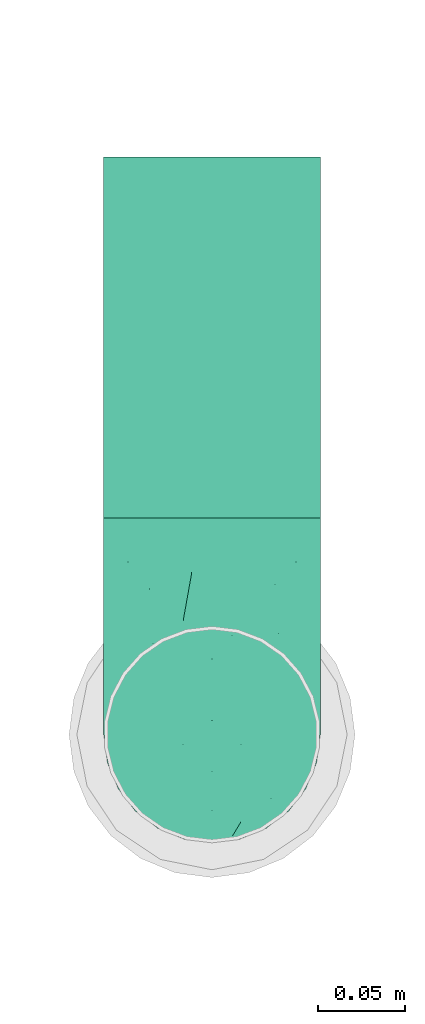
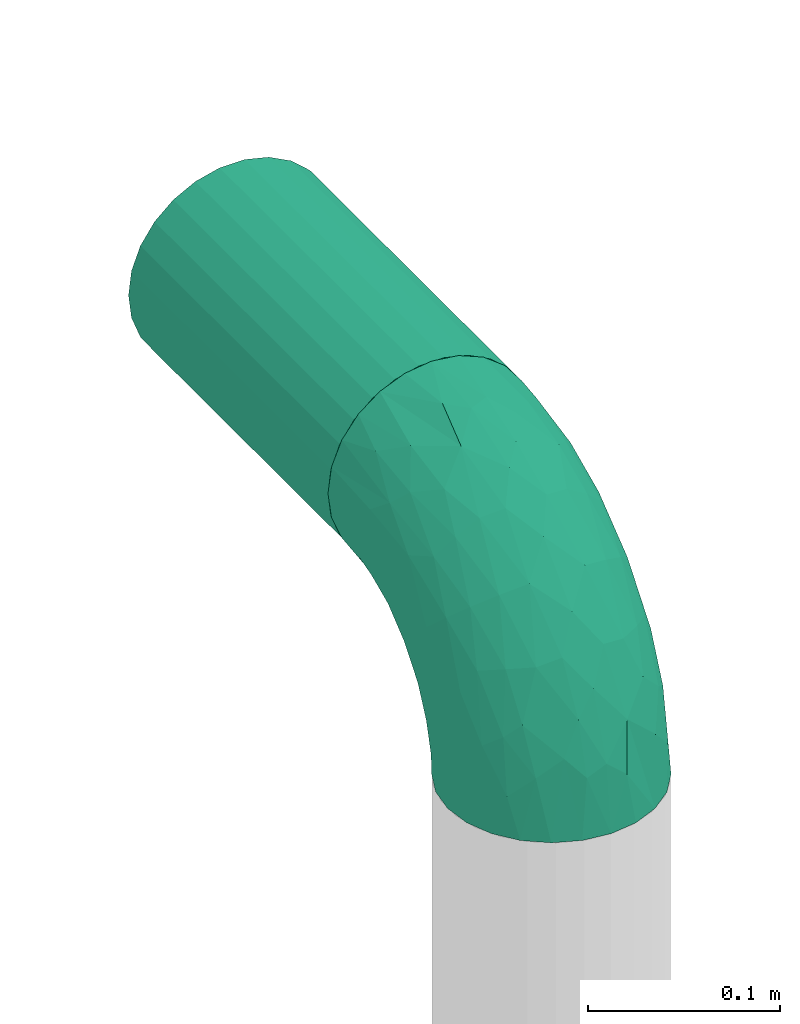
# One storey, part 51 of 103: 1 flow fitting, 1 flow segment.
"""IFC2X3 building model written with IfcOpenShell, lengths in millimetres."""

import ifcopenshell
import ifcopenshell.guid

model = None  # the IFC model being written
_history = None  # IfcOwnerHistory: only IFC2X3 demands one
_inside = {}  # id of a spatial element -> (the spatial element, [elements in it])
_under = {}  # id of a project, library or spatial element -> (it, [spatial elements below it])
_declared = {}  # id of a project -> (the project, [libraries it declares])
_typed = {}  # id of a type object -> (the type object, [elements of that type])
_made_of = {}  # id of a material, layer set ... -> (it, [elements and type objects made of it])


def new_model(schema):
    """Start an empty IFC model of exactly this schema.

    Asked for "IFC4X3", IfcOpenShell would pick the latest addendum, in which some entities
    have other attributes; the version numbers below select the first issue.
    IFC2X3 requires an IfcOwnerHistory on every rooted entity: one is made here for all.
    """
    global model, _history
    if schema == "IFC4X3":
        model = ifcopenshell.file(schema_version=(4, 3, 0, 0))
    else:
        model = ifcopenshell.file(schema=schema)
    _inside.clear()
    _under.clear()
    _declared.clear()
    _typed.clear()
    _made_of.clear()
    _history = None
    if model.schema == "IFC2X3":
        org = make("IfcOrganization", Name="unknown")
        user = make(
            "IfcPersonAndOrganization",
            ThePerson=make("IfcPerson", FamilyName="unknown"),
            TheOrganization=org,
        )
        app = make(
            "IfcApplication",
            ApplicationDeveloper=org,
            Version="unknown",
            ApplicationFullName="unknown",
            ApplicationIdentifier="unknown",
        )
        _history = make(
            "IfcOwnerHistory",
            OwningUser=user,
            OwningApplication=app,
            ChangeAction="ADDED",
            CreationDate=0,
        )
    return model


def make(cls, **values):
    """One entity of the class cls with the attributes given. An attribute that is None is left unset."""
    return model.create_entity(
        cls, **{name: value for name, value in values.items() if value is not None}
    )


def entity(cls, *values):
    """Any entity or typed value of the class cls, its attributes in the order of the schema. None: left unset."""
    e = model.create_entity(cls)
    for i, value in enumerate(values):
        if value is not None:
            e[i] = value
    return e


def rooted(cls, **values):
    """An entity with a GlobalId (a new one), such as an element, a storey or a relation."""
    return make(cls, GlobalId=ifcopenshell.guid.new(), OwnerHistory=_history, **values)


def si_unit(unit_type, name, prefix=None):
    """IfcSIUnit, for example si_unit("LENGTHUNIT", "METRE", prefix="MILLI")."""
    return make("IfcSIUnit", UnitType=unit_type, Prefix=prefix, Name=name)


def converted_unit(unit_type, name, factor, base, dimensions=None, offset=None):
    """IfcConversionBasedUnit, such as the inch: factor (a typed value) times the base unit."""
    return make(
        "IfcConversionBasedUnit"
        if offset is None
        else "IfcConversionBasedUnitWithOffset",
        ConversionOffset=offset,
        Dimensions=None
        if dimensions is None
        else entity("IfcDimensionalExponents", *dimensions),
        UnitType=unit_type,
        Name=name,
        ConversionFactor=make(
            "IfcMeasureWithUnit", ValueComponent=factor, UnitComponent=base
        ),
    )


def derived_unit(unit_type, elements):
    """IfcDerivedUnit: a product of units, each with its exponent."""
    return make(
        "IfcDerivedUnit",
        Elements=[
            make("IfcDerivedUnitElement", Unit=unit, Exponent=power)
            for unit, power in elements
        ],
        UnitType=unit_type,
    )


def assignment(units):
    """IfcUnitAssignment: the units of a project."""
    return None if units is None else make("IfcUnitAssignment", Units=units)


def point(xyz):
    """IfcCartesianPoint."""
    return None if xyz is None else make("IfcCartesianPoint", Coordinates=xyz)


def direction(xyz):
    """IfcDirection."""
    return None if xyz is None else make("IfcDirection", DirectionRatios=xyz)


def frame(location, z_axis=None, x_axis=None):
    """IfcAxis2Placement3D, a coordinate frame: its origin and axes. An axis left out is left unset."""
    return make(
        "IfcAxis2Placement3D",
        Location=point(location),
        Axis=direction(z_axis),
        RefDirection=direction(x_axis),
    )


def frame_2d(location, x_axis=None):
    """IfcAxis2Placement2D, a coordinate frame in the plane: its origin and x axis."""
    return make(
        "IfcAxis2Placement2D", Location=point(location), RefDirection=direction(x_axis)
    )


def origin_with_axes():
    """The frame at (0, 0, 0) with the z axis (0, 0, 1) and the x axis (1, 0, 0) written out."""
    return frame((0.0, 0.0, 0.0), z_axis=(0.0, 0.0, 1.0), x_axis=(1.0, 0.0, 0.0))


def origin_2d_with_axis():
    """The frame at (0, 0) in the plane with the x axis (1, 0) written out."""
    return frame_2d((0.0, 0.0), x_axis=(1.0, 0.0))


def place(relative_to, where):
    """IfcLocalPlacement: puts the frame where relative to a parent placement (None: the world)."""
    return make(
        "IfcLocalPlacement", PlacementRelTo=relative_to, RelativePlacement=where
    )


def context(
    kind, dimensions, precision=None, world=None, true_north=None, identifier=None
):
    """IfcGeometricRepresentationContext, for example the 3D "Model" context."""
    return make(
        "IfcGeometricRepresentationContext",
        ContextIdentifier=identifier,
        ContextType=kind,
        CoordinateSpaceDimension=dimensions,
        Precision=precision,
        WorldCoordinateSystem=world,
        TrueNorth=true_north,
    )


def subcontext(parent, identifier, kind, view, scale=None):
    """IfcGeometricRepresentationSubContext, for example "Body" below "Model"."""
    return make(
        "IfcGeometricRepresentationSubContext",
        ContextIdentifier=identifier,
        ContextType=kind,
        ParentContext=parent,
        TargetScale=scale,
        TargetView=view,
    )


def project(units=None, contexts=None):
    """IfcProject with its units and contexts."""
    return rooted(
        "IfcProject",
        Name="project",
        RepresentationContexts=contexts,
        UnitsInContext=assignment(units),
    )


def spatial(cls, under=None, at=None, **own):
    """A site, building, storey or space (cls), placed at a placement, below another one or the project."""
    s = rooted(cls, ObjectPlacement=at, **own)
    if under is not None:
        _under.setdefault(under.id(), (under, []))[1].append(s)
    return s


def profile(cls, at=None, kind="AREA", **sizes):
    """A parametric profile (cls). Its sizes go by their IFC names, for example OverallWidth=200.0."""
    return make(cls, ProfileType=kind, Position=at, **sizes)


def hollow_circle(**sizes):
    """IfcCircleHollowProfileDef."""
    return profile("IfcCircleHollowProfileDef", **sizes)


def extrude(swept, where, along, depth):
    """IfcExtrudedAreaSolid: the profile swept, set in the frame where, extruded along a direction by depth."""
    return make(
        "IfcExtrudedAreaSolid",
        SweptArea=swept,
        Position=where,
        ExtrudedDirection=direction(along),
        Depth=depth,
    )


def faces_of(points, faces, orient=None, outer=None):
    """IfcFace entities. A face is a list of loops; a loop is a list of indices into points, from 0.

    orient and outer hold one flag for each loop. By default every Orientation is true, the
    first loop of a face is its IfcFaceOuterBound and the others are IfcFaceBound.
    """
    made = []
    for i, loops in enumerate(faces):
        bounds = []
        for j, loop in enumerate(loops):
            is_outer = j == 0 if outer is None else outer[i][j]
            bounds.append(
                make(
                    "IfcFaceOuterBound" if is_outer else "IfcFaceBound",
                    Bound=make("IfcPolyLoop", Polygon=[points[k] for k in loop]),
                    Orientation=True if orient is None else orient[i][j],
                )
            )
        made.append(make("IfcFace", Bounds=bounds))
    return made


def open_shell(faces, orient=None, outer=None):
    """The faces of one IfcOpenShell. surface_model builds it on its shared points."""
    return ("IfcOpenShell", faces, orient, outer)


def surface_model(cls, points, shells):
    """IfcFaceBasedSurfaceModel or IfcShellBasedSurfaceModel (cls): surfaces that need not close."""
    shared = [point(p) for p in points]
    made = [make(c, CfsFaces=faces_of(shared, fs, o, b)) for c, fs, o, b in shells]
    if cls == "IfcFaceBasedSurfaceModel":
        return make(cls, FbsmFaces=made)
    return make(cls, SbsmBoundary=made)


def shape(context_of_items, identifier, shape_type, items):
    """IfcShapeRepresentation: the items that make up one representation, for example the "Body"."""
    return make(
        "IfcShapeRepresentation",
        ContextOfItems=context_of_items,
        RepresentationIdentifier=identifier,
        RepresentationType=shape_type,
        Items=items,
    )


def source(mapping_origin, context_of_items, identifier, shape_type, items):
    """IfcRepresentationMap: a shape defined once, which mapped items show again and again."""
    return make(
        "IfcRepresentationMap",
        MappingOrigin=mapping_origin,
        MappedRepresentation=shape(context_of_items, identifier, shape_type, items),
    )


def transform(
    local_origin,
    x_axis=None,
    y_axis=None,
    z_axis=None,
    scale=None,
    scale2=None,
    scale3=None,
    uniform=True,
):
    """IfcCartesianTransformationOperator3D, or its non-uniform kind. x_axis, y_axis, z_axis: its Axis1, 2, 3."""
    if uniform:
        return make(
            "IfcCartesianTransformationOperator3D",
            Axis1=direction(x_axis),
            Axis2=direction(y_axis),
            LocalOrigin=point(local_origin),
            Scale=scale,
            Axis3=direction(z_axis),
        )
    return make(
        "IfcCartesianTransformationOperator3DnonUniform",
        Axis1=direction(x_axis),
        Axis2=direction(y_axis),
        LocalOrigin=point(local_origin),
        Scale=scale,
        Axis3=direction(z_axis),
        Scale2=scale2,
        Scale3=scale3,
    )


def mapped(mapping_source, mapping_target):
    """IfcMappedItem: shows the shape of a source again, moved by a transform."""
    return make(
        "IfcMappedItem", MappingSource=mapping_source, MappingTarget=mapping_target
    )


def material(Name=None, Category=None):
    """IfcMaterial."""
    return make("IfcMaterial", Name=Name, Category=Category)


def layer(
    of_material, thickness, ventilated=None, Name=None, Category=None, Priority=None
):
    """IfcMaterialLayer: one layer of a wall or slab, of a material (None: an air gap)."""
    return make(
        "IfcMaterialLayer",
        Material=of_material,
        LayerThickness=thickness,
        IsVentilated=ventilated,
        Name=Name,
        Category=Category,
        Priority=Priority,
    )


def layer_set(layers, Name=None):
    """IfcMaterialLayerSet."""
    return make("IfcMaterialLayerSet", MaterialLayers=layers, LayerSetName=Name)


def layer_usage(for_layer_set, set_direction, sense, offset, extent=None):
    """IfcMaterialLayerSetUsage: how a layer set lies in its element."""
    return make(
        "IfcMaterialLayerSetUsage",
        ForLayerSet=for_layer_set,
        LayerSetDirection=set_direction,
        DirectionSense=sense,
        OffsetFromReferenceLine=offset,
        ReferenceExtent=extent,
    )


def made_of(thing, what):
    """Note that an element or type object is made of a material, layer set ...; save() writes the relation."""
    if what is not None:
        _made_of.setdefault(what.id(), (what, []))[1].append(thing)
    return thing


def type_object(cls, material=None, **own):
    """A type object (cls), such as IfcWallType, which elements share."""
    return made_of(rooted(cls, **own), material)


def element(
    cls,
    number,
    at=None,
    inside=None,
    cuts=None,
    type_object=None,
    material=None,
    context=None,
    identifier="Body",
    shape_type=None,
    held_by="IfcProductDefinitionShape",
    body=None,
    shapes=None,
    **own,
):
    """One element of the class cls, such as IfcWall. Its Tag is "e" and its number.

    at: its placement. inside: the storey or other place that contains it. cuts: it is an
    opening in that element (IfcRelVoidsElement). A single representation is given by context,
    identifier, shape_type and body (its items); several are given by shapes. held_by: the class
    of the entity that holds the representations. save() writes the other relations.
    """
    e = rooted(cls, Tag="e%d" % number, ObjectPlacement=at, **own)
    if body is not None:
        shapes = [shape(context, identifier, shape_type, body)]
    if shapes is not None:
        e.Representation = make(held_by, Representations=shapes)
    if inside is not None:
        _inside.setdefault(inside.id(), (inside, []))[1].append(e)
    if cuts is not None:
        rooted(
            "IfcRelVoidsElement", RelatingBuildingElement=cuts, RelatedOpeningElement=e
        )
    if type_object is not None:
        _typed.setdefault(type_object.id(), (type_object, []))[1].append(e)
    return made_of(e, material)


def aggregate(whole, parts):
    """IfcRelAggregates: a whole, such as a stair, and the parts it consists of."""
    return rooted("IfcRelAggregates", RelatingObject=whole, RelatedObjects=parts)


def save(model, path):
    """Write the relations noted so far, then the file.

    IfcRelAggregates (storeys below a building ...), IfcRelContainedInSpatialStructure (elements
    in a storey), IfcRelDefinesByType, IfcRelAssociatesMaterial and IfcRelDeclares: one each for
    every whole, place, type object, material and project.
    """
    for whole, parts in _under.values():
        aggregate(whole, parts)
    for where, things in _inside.values():
        rooted(
            "IfcRelContainedInSpatialStructure",
            RelatedElements=things,
            RelatingStructure=where,
        )
    for kind, things in _typed.values():
        rooted("IfcRelDefinesByType", RelatedObjects=things, RelatingType=kind)
    for what, things in _made_of.values():
        rooted("IfcRelAssociatesMaterial", RelatedObjects=things, RelatingMaterial=what)
    for by, libraries in _declared.values():
        rooted("IfcRelDeclares", RelatingContext=by, RelatedDefinitions=libraries)
    model.write(path)


model = new_model("IFC2X3")

# Units and contexts
model_context = context("Model", 3, precision=1e-05, world=origin_with_axes(), true_north=direction((0.0, 1.0)))
body_context = subcontext(model_context, "Body", "Model", "MODEL_VIEW")
ifc_project = project(units=[si_unit("AREAUNIT", "SQUARE_METRE"), si_unit("VOLUMEUNIT", "CUBIC_METRE", prefix="DECI"), si_unit("TIMEUNIT", "SECOND"), si_unit("THERMODYNAMICTEMPERATUREUNIT", "DEGREE_CELSIUS"), si_unit("PRESSUREUNIT", "PASCAL"), si_unit("MASSUNIT", "GRAM", prefix="KILO"), si_unit("LENGTHUNIT", "METRE", prefix="MILLI"), si_unit("POWERUNIT", "WATT"), si_unit("ELECTRICCURRENTUNIT", "AMPERE"), si_unit("ELECTRICVOLTAGEUNIT", "VOLT"), derived_unit("VOLUMETRICFLOWRATEUNIT", [(si_unit("VOLUMEUNIT", "CUBIC_METRE", prefix="DECI"), 1), (si_unit("TIMEUNIT", "SECOND"), -1)]), derived_unit("LINEARVELOCITYUNIT", [(si_unit("LENGTHUNIT", "METRE"), 1), (si_unit("TIMEUNIT", "SECOND"), -1)]), derived_unit("MASSDENSITYUNIT", [(si_unit("MASSUNIT", "GRAM", prefix="KILO"), 1), (si_unit("VOLUMEUNIT", "CUBIC_METRE"), -1)]), converted_unit("PLANEANGLEUNIT", "DEGREE", entity("IfcRatioMeasure", 0.01745), si_unit("PLANEANGLEUNIT", "RADIAN"), dimensions=[0, 0, 0, 0, 0, 0, 0])], contexts=[model_context])

# Site, building, storey
site_placement = place(None, origin_with_axes())
site = spatial("IfcSite", under=ifc_project, at=site_placement, CompositionType="ELEMENT")
building_placement = place(site_placement, origin_with_axes())
building = spatial("IfcBuilding", under=site, at=building_placement, Name="mc-building", CompositionType="ELEMENT")
storey_placement = place(building_placement, frame((0.0, 0.0, 5900.0), z_axis=(0.0, 0.0, 1.0), x_axis=(1.0, 0.0, 0.0)))
storey = spatial("IfcBuildingStorey", under=building, at=storey_placement, Name="3. Korrus", CompositionType="ELEMENT", Elevation=5900.0)

# Flow fitting
duct_fitting_type = type_object("IfcDuctFittingType", Name="BU", PredefinedType="BEND")
shared_shape_1 = source(origin_with_axes(), body_context, "Body", "SurfaceModel", [
    surface_model("IfcShellBasedSurfaceModel", [(-125.0, 0.0, -62.5), (-125.0, -16.17619, -60.37037), (-125.0, 16.17619, -60.37037), (-125.0, 60.37037, 16.17619), (-125.0, 31.25, -54.12659), (-125.0, 54.12659, -31.25), (-125.0, 44.19417, -44.19417), (-125.0, -62.5, 0.0), (-125.0, -60.37037, 16.17619), (-125.0, -44.19417, -44.19417), (-125.0, -31.25, -54.12659), (-125.0, -60.37037, -16.17619), (-125.0, -54.12659, -31.25), (-125.0, 60.37037, -16.17619), (-125.0, 54.12659, 31.25), (-125.0, 44.19417, 44.19417), (-125.0, 16.17619, 60.37037), (-125.0, 31.25, 54.12659), (-125.0, -16.17619, 60.37037), (-125.0, -54.12659, 31.25), (-125.0, -44.19417, 44.19417), (-125.0, -31.25, 54.12659), (-125.0, 0.0, 62.5), (-125.0, 62.5, 0.0), (-16.17619, 125.0, -60.37037), (-62.5, 125.0, 0.0), (0.0, 125.0, -62.5), (-31.25, 125.0, -54.12659), (-44.19417, 125.0, -44.19417), (-54.12659, 125.0, -31.25), (44.19417, 125.0, -44.19417), (60.37037, 125.0, 16.17619), (31.25, 125.0, -54.12659), (16.17619, 125.0, -60.37037), (54.12659, 125.0, -31.25), (60.37037, 125.0, -16.17619), (62.5, 125.0, 0.0), (-60.37037, 125.0, -16.17619), (-60.37037, 125.0, 16.17619), (-54.12659, 125.0, 31.25), (-44.19417, 125.0, 44.19417), (-31.25, 125.0, 54.12659), (0.0, 125.0, 62.5), (-16.17619, 125.0, 60.37037), (54.12659, 125.0, 31.25), (44.19417, 125.0, 44.19417), (31.25, 125.0, 54.12659), (16.17619, 125.0, 60.37037), (-72.97423, 55.32904, 49.58459), (-87.09148, 43.38651, 51.77259), (-68.69218, 37.01083, 59.02974), (-86.37288, 6.11794, 62.5), (-102.44946, 13.57266, 61.46748), (-89.31796, 30.42505, 57.74247), (-79.75876, 21.08139, 61.40263), (-85.85709, 61.60432, 36.83247), (-105.99571, 52.01835, 38.04759), (-109.23107, 25.15527, 57.74247), (-23.87288, 51.52684, 62.5), (-20.86657, 80.09577, 61.41459), (-36.41116, 67.77294, 59.36871), (-72.59833, 84.97566, 20.44471), (-84.84527, 71.68644, 22.63776), (-72.28039, 75.08953, 34.06229), (-113.17841, 59.9112, 21.05599), (-105.80839, 64.31191, 11.93589), (-111.60883, 65.16367, 0.0), (-60.71426, 105.22832, 23.91771), (-100.62332, 62.31546, 23.91771), (-13.4791, 102.54506, 61.48083), (-6.11794, 86.37288, 62.5), (-65.16367, 111.60883, 0.0), (-64.37068, 105.82697, 11.61464), (-51.52684, 23.87288, 62.5), (-50.69134, 50.69135, 59.24335), (-105.32369, 40.3031, 49.58458), (-25.28712, 108.41778, 57.74247), (-40.88389, 102.97269, 49.58458), (-49.66967, 79.07581, 50.53579), (-30.95126, 87.95323, 57.74247), (-65.09409, 90.12761, 28.38341), (-66.67939, 95.80824, 18.23245), (-94.24179, 68.59274, 14.67936), (-56.68565, 61.95245, 53.66363), (-84.74719, 75.95181, 10.86071), (-51.54332, 107.92365, 38.04759), (-67.25753, 101.08228, 0.0), (-58.54205, 89.35136, 38.04759), (-74.03168, 90.94406, 0.0), (-64.15138, 70.52814, 45.04029), (-101.08228, 67.25753, 0.0), (-80.80582, 80.80582, 0.0), (-90.94406, 74.03168, 0.0), (-107.87602, 51.55441, -38.04759), (-105.81087, 64.31979, -11.89334), (-113.23859, 59.9943, -20.79563), (-102.50484, 41.0078, -49.58458), (-90.90834, 52.91787, -43.09941), (-86.37288, 6.11794, -62.5), (-82.6746, 22.37103, -60.91508), (-51.52684, 23.87288, -62.5), (-24.90859, 74.00088, -61.20337), (-6.11794, 86.37288, -62.5), (-23.87288, 51.52684, -62.5), (-40.24859, 105.55983, -49.58458), (-103.52624, 12.53143, -61.61172), (-52.01835, 105.9957, -38.04759), (-102.84629, 26.37525, -57.74247), (-80.60061, 37.86129, -56.26993), (-89.23788, 71.99576, -13.34087), (-28.31259, 95.51825, -57.74247), (-100.89706, 62.20969, -23.91771), (-79.09001, 65.16893, -38.04759), (-83.36843, 70.98492, -26.07025), (-72.14843, 76.80808, -32.35146), (-64.31191, 105.80839, -11.93589), (-62.31546, 100.62332, -23.91771), (-61.48499, 86.19979, -36.72576), (-65.63586, 35.3365, -60.01002), (-59.9112, 113.17841, -21.05599), (-14.35128, 101.66255, -61.35337), (-39.16846, 75.52412, -56.86737), (-49.98148, 49.98148, -59.57135), (-74.75599, 82.48123, -20.09995), (-79.93714, 49.60562, -50.24944), (-65.30683, 59.08485, -51.03937), (-69.00621, 93.51335, -14.6428), (-48.12403, 84.36987, -49.58459), (-65.05902, 72.16091, -43.27513), (-91.99255, 60.8749, -33.31849), (-74.30538, -22.05025, -54.52849), (-83.27732, -57.79898, 0.0), (-93.43528, -58.70511, -11.68929), (-65.26967, -50.32842, -16.71444), (20.96007, 31.53005, -39.63719), (36.17209, 58.4237, -38.31102), (29.66468, 29.66696, -26.32537), (-59.46467, 5.17337, -61.41841), (9.88584, 35.44281, -50.43749), (-6.21876, 6.21876, -45.37394), (1.26602, -1.26602, -32.1996), (5.97284, -5.97284, -16.71444), (-29.66696, -29.66468, -26.32537), (-5.17337, 59.46467, -61.41841), (-25.56296, 25.56296, -60.51531), (-85.76554, -12.75621, -59.78088), (48.55289, 56.98302, -11.64673), (57.71969, 88.32124, -11.85826), (57.79898, 83.27732, 0.0), (-8.09566, -21.5934, 0.0), (-43.6468, -43.93166, 0.0), (-26.3245, -32.97333, -12.3928), (-83.98915, -46.13442, -36.15679), (-66.40639, -30.82245, -46.75569), (-31.53004, -20.96006, -39.63719), (-52.51367, -36.89027, -34.10077), (12.75621, 85.76554, -59.78088), (4.48155, 49.92421, -57.42403), (37.53998, 99.49287, -48.41169), (22.05025, 74.30538, -54.52849), (-15.22434, 15.22435, -54.69384), (-49.9242, -4.48154, -57.42403), (51.83554, 76.17092, -22.12398), (46.66757, 86.70304, -36.28653), (-35.4428, -9.88583, -50.43749), (21.5934, 8.09566, 0.0), (43.93166, 43.6468, 0.0), (32.97333, 26.3245, -12.3928), (-99.49287, -37.53998, -48.41169), (30.82245, 66.40639, -46.75569), (-56.98302, -48.55289, 11.64673), (-88.32124, -57.71969, 11.85826), (50.32842, 65.26967, 16.71444), (-76.17092, -51.83554, 22.12398), (-5.17337, 59.46467, 61.41841), (12.75621, 85.76554, 59.78088), (-85.76554, -12.75621, 59.78088), (-49.9242, -4.48154, 57.42403), (-59.46467, 5.17337, 61.41841), (-26.3245, -32.97333, 12.3928), (-35.4428, -9.88583, 50.43749), (-31.53004, -20.96006, 39.63719), (-6.21876, 6.21876, 45.37394), (32.97333, 26.3245, 12.3928), (5.97284, -5.97284, 16.71444), (-99.49287, -37.53998, 48.41169), (-86.70304, -46.66757, 36.28653), (9.88584, 35.44281, 50.43749), (20.96007, 31.53005, 39.63719), (-15.22434, 15.22435, 54.69384), (4.48155, 49.92421, 57.42403), (-74.30538, -22.05025, 54.52849), (-25.56296, 25.56296, 60.51531), (37.53998, 99.49287, 48.41169), (46.13442, 83.98915, 36.15679), (29.66468, 29.66696, 26.32537), (-29.66696, -29.66468, 26.32537), (1.26602, -1.26602, 32.1996), (58.70511, 93.43528, 11.68929), (30.82245, 66.40639, 46.75569), (36.89027, 52.51367, 34.10076), (22.05025, 74.30538, 54.52849), (-58.42369, -36.17209, 38.31102), (-66.40639, -30.82245, 46.75569)], [open_shell([[[0, 1, 2]], [[2, 3, 4]], [[5, 6, 3]], [[4, 3, 6]], [[2, 7, 8]], [[9, 7, 10]], [[1, 10, 7]], [[11, 7, 12]], [[9, 12, 7]], [[7, 2, 1]], [[5, 3, 13]], [[14, 3, 2]], [[15, 14, 2]], [[2, 16, 17]], [[17, 15, 2]], [[2, 18, 16]], [[2, 8, 19]], [[2, 19, 20]], [[20, 21, 2]], [[18, 2, 21]], [[18, 22, 16]], [[23, 13, 3]], [[24, 25, 26]], [[27, 25, 24]], [[25, 28, 29]], [[28, 25, 27]], [[30, 26, 31]], [[26, 32, 33]], [[26, 30, 32]], [[30, 31, 34]], [[34, 31, 35]], [[31, 36, 35]], [[29, 37, 25]], [[38, 39, 26]], [[39, 40, 26]], [[26, 41, 42]], [[41, 26, 40]], [[41, 43, 42]], [[44, 31, 26]], [[45, 44, 26]], [[26, 46, 45]], [[47, 46, 26]], [[47, 26, 42]], [[25, 38, 26]], [[48, 49, 50]], [[22, 51, 52]], [[53, 54, 50]], [[55, 56, 49]], [[56, 14, 15]], [[16, 57, 17]], [[58, 59, 60]], [[61, 62, 63]], [[3, 64, 65]], [[53, 52, 54]], [[3, 65, 66]], [[67, 39, 38]], [[56, 68, 64]], [[65, 64, 68]], [[69, 59, 70]], [[38, 71, 72]], [[73, 58, 74]], [[75, 49, 56]], [[76, 69, 43]], [[53, 57, 52]], [[77, 78, 79]], [[41, 76, 43]], [[43, 69, 42]], [[55, 68, 56]], [[15, 17, 75]], [[76, 77, 79]], [[80, 67, 81]], [[62, 82, 68]], [[60, 78, 83]], [[62, 84, 82]], [[85, 77, 40]], [[81, 67, 72]], [[86, 72, 71]], [[87, 85, 67]], [[61, 81, 88]], [[77, 41, 40]], [[78, 77, 87]], [[15, 75, 56]], [[83, 89, 48]], [[85, 40, 39]], [[62, 68, 55]], [[89, 87, 63]], [[83, 48, 50]], [[57, 75, 17]], [[49, 75, 53]], [[67, 85, 39]], [[87, 77, 85]], [[63, 62, 55]], [[89, 55, 48]], [[80, 63, 87]], [[66, 65, 90]], [[66, 23, 3]], [[84, 91, 92]], [[92, 90, 82]], [[65, 82, 90]], [[61, 84, 62]], [[92, 82, 84]], [[68, 82, 65]], [[3, 14, 64]], [[56, 64, 14]], [[38, 25, 71]], [[81, 72, 86]], [[38, 72, 67]], [[91, 61, 88]], [[80, 81, 61]], [[63, 80, 61]], [[67, 80, 87]], [[77, 76, 41]], [[79, 59, 69]], [[79, 69, 76]], [[42, 69, 70]], [[60, 59, 79]], [[58, 70, 59]], [[78, 60, 79]], [[58, 60, 74]], [[52, 57, 16]], [[75, 57, 53]], [[22, 52, 16]], [[52, 51, 54]], [[51, 73, 54]], [[50, 73, 74]], [[73, 50, 54]], [[50, 74, 83]], [[60, 83, 74]], [[89, 83, 78]], [[87, 89, 78]], [[55, 89, 63]], [[50, 49, 53]], [[55, 49, 48]], [[81, 86, 88]], [[91, 84, 61]], [[6, 5, 93]], [[90, 94, 66]], [[13, 94, 95]], [[96, 93, 97]], [[98, 99, 100]], [[96, 4, 6]], [[101, 102, 103]], [[28, 27, 104]], [[2, 105, 0]], [[104, 106, 28]], [[99, 105, 107]], [[108, 107, 96]], [[90, 109, 94]], [[107, 2, 4]], [[13, 66, 94]], [[27, 24, 110]], [[109, 111, 94]], [[112, 113, 114]], [[37, 115, 71]], [[116, 106, 117]], [[99, 118, 100]], [[116, 115, 119]], [[37, 119, 115]], [[24, 120, 110]], [[121, 110, 101]], [[119, 106, 116]], [[101, 110, 120]], [[122, 103, 100]], [[117, 123, 116]], [[124, 125, 108]], [[115, 116, 126]], [[106, 29, 28]], [[26, 102, 120]], [[127, 104, 110]], [[97, 124, 96]], [[125, 122, 118]], [[128, 127, 125]], [[96, 6, 93]], [[115, 126, 86]], [[117, 106, 127]], [[111, 113, 129]], [[95, 93, 5]], [[97, 129, 112]], [[110, 104, 27]], [[106, 104, 127]], [[96, 107, 4]], [[99, 107, 108]], [[99, 108, 118]], [[105, 99, 98]], [[112, 114, 128]], [[121, 125, 127]], [[13, 23, 66]], [[109, 90, 92]], [[94, 111, 95]], [[91, 123, 109]], [[129, 113, 112]], [[93, 95, 111]], [[5, 13, 95]], [[71, 115, 86]], [[71, 25, 37]], [[123, 91, 88]], [[126, 116, 123]], [[123, 88, 126]], [[86, 126, 88]], [[37, 29, 119]], [[106, 119, 29]], [[129, 93, 111]], [[124, 112, 125]], [[0, 105, 98]], [[107, 105, 2]], [[125, 118, 108]], [[100, 118, 122]], [[93, 129, 97]], [[113, 111, 109]], [[109, 123, 113]], [[114, 123, 117]], [[123, 114, 113]], [[128, 114, 117]], [[127, 128, 117]], [[112, 128, 125]], [[103, 122, 101]], [[110, 121, 127]], [[101, 122, 121]], [[125, 121, 122]], [[26, 120, 24]], [[101, 120, 102]], [[96, 124, 108]], [[92, 91, 109]], [[112, 124, 97]], [[10, 1, 130]], [[131, 132, 133]], [[134, 135, 136]], [[98, 100, 137]], [[138, 134, 139]], [[140, 141, 142]], [[143, 144, 103]], [[98, 145, 0]], [[146, 147, 148]], [[149, 150, 151]], [[7, 11, 132]], [[133, 12, 152]], [[153, 154, 155]], [[152, 12, 9]], [[156, 157, 143]], [[142, 151, 133]], [[155, 133, 152]], [[158, 159, 32]], [[136, 141, 140]], [[137, 145, 98]], [[103, 144, 100]], [[133, 132, 12]], [[160, 161, 144]], [[137, 144, 161]], [[160, 144, 157]], [[156, 26, 33]], [[130, 1, 145]], [[34, 162, 163]], [[164, 139, 154]], [[30, 158, 32]], [[160, 138, 139]], [[163, 30, 34]], [[156, 159, 157]], [[149, 141, 165]], [[146, 166, 167]], [[168, 9, 10]], [[36, 148, 147]], [[9, 168, 152]], [[150, 131, 133]], [[166, 146, 148]], [[166, 165, 167]], [[141, 136, 167]], [[160, 164, 161]], [[143, 103, 102]], [[151, 141, 149]], [[35, 162, 34]], [[135, 162, 136]], [[158, 163, 169]], [[144, 137, 100]], [[145, 137, 161]], [[145, 161, 130]], [[145, 1, 0]], [[102, 26, 156]], [[144, 143, 157]], [[102, 156, 143]], [[159, 33, 32]], [[141, 167, 165]], [[146, 136, 162]], [[133, 151, 150]], [[141, 151, 142]], [[164, 130, 161]], [[130, 153, 168]], [[159, 156, 33]], [[138, 159, 169]], [[138, 160, 157]], [[164, 160, 139]], [[154, 140, 142]], [[134, 140, 139]], [[159, 138, 157]], [[134, 136, 140]], [[138, 169, 134]], [[135, 134, 169]], [[139, 140, 154]], [[130, 164, 153]], [[155, 154, 142]], [[153, 164, 154]], [[136, 146, 167]], [[146, 162, 147]], [[162, 35, 147]], [[36, 147, 35]], [[130, 168, 10]], [[152, 168, 153]], [[163, 158, 30]], [[159, 158, 169]], [[7, 132, 131]], [[12, 132, 11]], [[169, 163, 135]], [[135, 163, 162]], [[133, 155, 142]], [[153, 155, 152]], [[150, 170, 131]], [[171, 7, 131]], [[166, 148, 172]], [[8, 173, 19]], [[174, 175, 70]], [[176, 177, 178]], [[149, 179, 150]], [[170, 150, 179]], [[180, 181, 182]], [[165, 183, 184]], [[20, 185, 21]], [[20, 19, 186]], [[187, 182, 188]], [[189, 187, 190]], [[185, 191, 21]], [[22, 18, 176]], [[190, 192, 189]], [[189, 180, 182]], [[178, 73, 51]], [[19, 173, 186]], [[149, 165, 184]], [[45, 193, 194]], [[191, 177, 176]], [[165, 166, 183]], [[195, 183, 172]], [[196, 184, 197]], [[194, 44, 45]], [[198, 36, 31]], [[199, 188, 200]], [[172, 198, 44]], [[193, 45, 46]], [[194, 200, 172]], [[175, 42, 70]], [[192, 58, 73]], [[170, 171, 131]], [[189, 192, 177]], [[70, 58, 174]], [[190, 174, 192]], [[179, 184, 196]], [[197, 184, 195]], [[47, 201, 46]], [[181, 202, 196]], [[148, 198, 172]], [[201, 47, 175]], [[172, 44, 194]], [[178, 192, 73]], [[202, 173, 196]], [[185, 186, 203]], [[192, 174, 58]], [[175, 174, 190]], [[175, 190, 201]], [[175, 47, 42]], [[51, 22, 176]], [[192, 178, 177]], [[51, 176, 178]], [[191, 18, 21]], [[184, 179, 149]], [[170, 196, 173]], [[172, 183, 166]], [[184, 183, 195]], [[187, 201, 190]], [[201, 199, 193]], [[191, 176, 18]], [[180, 191, 203]], [[180, 189, 177]], [[187, 189, 182]], [[188, 197, 195]], [[181, 197, 182]], [[191, 180, 177]], [[181, 196, 197]], [[180, 203, 181]], [[202, 181, 203]], [[182, 197, 188]], [[201, 187, 199]], [[200, 188, 195]], [[199, 187, 188]], [[196, 170, 179]], [[170, 173, 171]], [[173, 8, 171]], [[7, 171, 8]], [[201, 193, 46]], [[194, 193, 199]], [[186, 185, 20]], [[191, 185, 203]], [[36, 198, 148]], [[44, 198, 31]], [[203, 186, 202]], [[202, 186, 173]], [[172, 200, 195]], [[199, 200, 194]]])]),
])
flow_fitting_placement = place(storey_placement, frame((20500.0937, 2567.93182, 4144.0), z_axis=(-1.0, 0.0, 0.0), x_axis=(0.0, 0.0, 1.0)))
element("IfcFlowFitting", 1, at=flow_fitting_placement, inside=storey, type_object=duct_fitting_type, Name="BU", context=body_context, shape_type="MappedRepresentation", body=[
    mapped(shared_shape_1, transform((0.0, 0.0, 0.0), scale=1.0)),
])

# Flow segment
ifc_material = material(Name="FZ1")
ifc_layer = layer(ifc_material, 0.0)
ifc_layer_set = layer_set([ifc_layer], Name="FZ1")
ifc_layer_usage = layer_usage(ifc_layer_set, "AXIS1", "POSITIVE", 0.0)
duct_segment_type = type_object("IfcDuctSegmentType", Name="Safe", PredefinedType="RIGIDSEGMENT")
shared_shape_2 = source(origin_with_axes(), body_context, "Body", "SweptSolid", [
    extrude(hollow_circle(Radius=62.5, WallThickness=2.0, at=origin_2d_with_axis()), frame((0.0, 0.0, 0.0), z_axis=(1.0, 0.0, 0.0), x_axis=(0.0, 1.0, 0.0)), (0.0, 0.0, 1.0), 208.3),
])
flow_segment_placement = place(storey_placement, frame((20500.0937, 2901.20513, 4144.0), z_axis=(0.0, 0.0, 1.0), x_axis=(0.0, -1.0, 0.0)))
element("IfcFlowSegment", 2, at=flow_segment_placement, inside=storey, type_object=duct_segment_type, material=ifc_layer_usage, Name="Safe", context=body_context, shape_type="MappedRepresentation", body=[
    mapped(shared_shape_2, transform((0.0, 0.0, 0.0), scale=1.0)),
])

save(model, "model.ifc")
